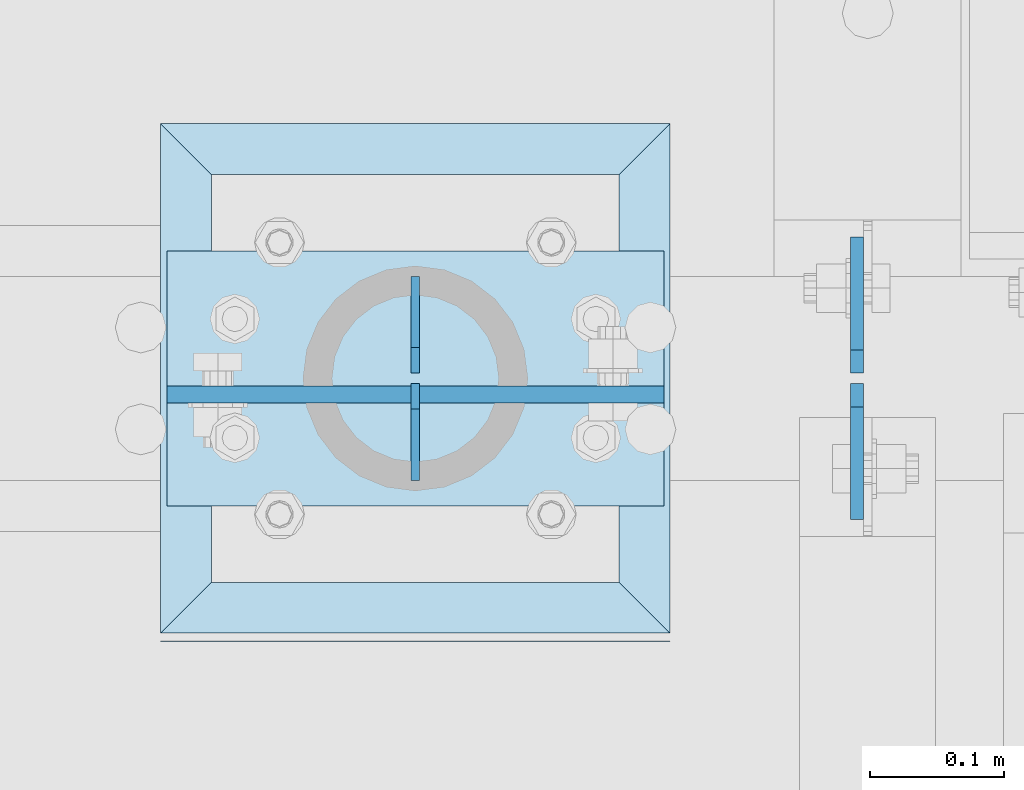
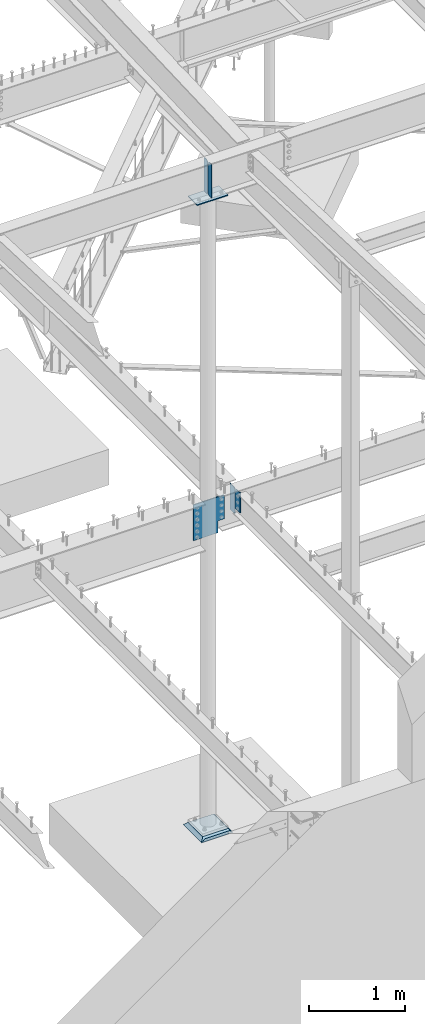
# One storey, part 851 of 975: 7 plates.
"""IFC2X3 building model written with IfcOpenShell, lengths in millimetres."""

from ifc_helpers import new_model, si_unit, frame, origin_with_axes, place, context, subcontext, project, spatial, faceted_brep, material, type_object, element, save


model = new_model("IFC2X3")

# Units and contexts
model_context = context("Model", 3, precision=1e-05, world=origin_with_axes())
body_context = subcontext(model_context, "Body", "Model", "MODEL_VIEW")
ifc_project = project(units=[si_unit("LENGTHUNIT", "METRE", prefix="MILLI"), si_unit("AREAUNIT", "SQUARE_METRE"), si_unit("VOLUMEUNIT", "CUBIC_METRE"), si_unit("MASSUNIT", "GRAM", prefix="KILO"), si_unit("TIMEUNIT", "SECOND"), si_unit("PLANEANGLEUNIT", "RADIAN"), si_unit("SOLIDANGLEUNIT", "STERADIAN"), si_unit("THERMODYNAMICTEMPERATUREUNIT", "DEGREE_CELSIUS"), si_unit("LUMINOUSINTENSITYUNIT", "LUMEN")], contexts=[model_context])

# Site, building, storey
site_placement = place(None, origin_with_axes())
site = spatial("IfcSite", under=ifc_project, at=site_placement, CompositionType="ELEMENT")
building_placement = place(site_placement, origin_with_axes())
building = spatial("IfcBuilding", under=site, at=building_placement, Name="Undefined", CompositionType="ELEMENT")
storey_placement = place(building_placement, origin_with_axes())
storey = spatial("IfcBuildingStorey", under=building, at=storey_placement, Name="Undefined", CompositionType="ELEMENT", Elevation=0.0)

# Plates
ifc_material_1 = material(Name="STEEL/A36")
plate_type_1 = type_object("IfcPlateType", PredefinedType="NOTDEFINED")
plate_1_placement = place(storey_placement, frame((23563.2620000839, 5815.80625, 3670.29999943227), z_axis=(0.0, 0.0, 1.0), x_axis=(0.0, -1.0, 0.0)))
element("IfcPlate", 1, at=plate_1_placement, inside=storey, type_object=plate_type_1, material=ifc_material_1, Name="PLATE", context=body_context, shape_type="Brep", body=[
    faceted_brep([(0.0, -4.76250000000073, 0.0), (0.0, -4.76250000000073, 238.124994277954), (0.0, 4.76250000000073, 238.124994277954), (0.0, 4.76250000000073, 0.0), (17.4624996185303, -4.76250000000073, 255.587493896484), (17.4624996185303, 4.76250000000073, 255.587493896484), (101.600006103508, -4.76250000004075, 255.587493896484), (101.600006103516, 4.76249999995707, 255.587493896484), (101.600006103516, -4.76250000000073, 0.0), (101.600006103516, 4.76250000000073, 0.0)], [[[0, 1, 2, 3]], [[1, 4, 5, 2]], [[4, 6, 7, 5]], [[6, 8, 9, 7]], [[8, 0, 3, 9]], [[5, 7, 9, 3, 2]], [[8, 6, 4, 1, 0]]]),
])
plate_2_placement = place(storey_placement, frame((23563.2625, 5823.74375, 3594.09999943227), z_axis=(0.0, 0.0, 1.0), x_axis=(0.0, 1.0, 0.0)))
element("IfcPlate", 2, at=plate_2_placement, inside=storey, type_object=plate_type_1, material=ifc_material_1, Name="PLATE", context=body_context, shape_type="Brep", body=[
    faceted_brep([(0.0, -4.76250000000073, 0.0), (0.0, -4.76249999999982, 314.325006484985), (0.0, 4.76249999999982, 314.325006484985), (0.0, 4.76250000000073, 0.0), (17.4624996185303, -4.76249999999982, 331.787506103516), (17.4624996185303, 4.76249999999982, 331.787506103516), (101.600006103516, -4.76249999999982, 331.787506103516), (101.600006103516, 4.76249999999982, 331.787506103516), (101.600006103516, -4.76250000000073, 0.0), (101.600006103516, 4.76250000000073, 0.0)], [[[0, 1, 2, 3]], [[1, 4, 5, 2]], [[4, 6, 7, 5]], [[6, 8, 9, 7]], [[8, 0, 3, 9]], [[5, 7, 9, 3, 2]], [[8, 6, 4, 1, 0]]]),
])
plate_type_2 = type_object("IfcPlateType", PredefinedType="NOTDEFINED")
for number, where, z_axis, x_axis, name in (
    (3, (23233.0625, 5743.575, 8218.4875), (0.0, 0.0, -1.0), (0.0, 1.0, 0.0), "PLATE"),
    (4, (23233.0625, 5895.975, 8218.4875), (0.0, 0.0, -1.0), (0.0, -1.0, 0.0), "PLATE"),
):
    element("IfcPlate", number, at=place(storey_placement, frame(where, z_axis=z_axis, x_axis=x_axis)), inside=storey, type_object=plate_type_2, material=ifc_material_1, Name=name, context=body_context, shape_type="Brep", body=[
        faceted_brep([(0.0, -3.17499999999927, 0.0), (0.0, -3.17499999999927, 428.625), (0.0, 3.17499999999927, 428.625), (0.0, 3.17499999999927, 0.0), (53.1812477111816, -3.17499999999927, 428.625), (53.1812477111816, 3.17499999999927, 428.625), (72.2312469482422, -3.17499999999927, 409.575000762939), (72.2312469482422, 3.17499999999927, 409.575000762939), (72.2312469482422, -3.17499999999927, 19.0499992370605), (72.2312469482422, 3.17499999999927, 19.0499992370605), (53.1812477111816, -3.17499999999927, 0.0), (53.1812477111816, 3.17499999999927, 0.0)], [[[0, 1, 2, 3]], [[1, 4, 5, 2]], [[4, 6, 7, 5]], [[6, 8, 9, 7]], [[8, 10, 11, 9]], [[10, 0, 3, 11]], [[5, 7, 9, 11, 3, 2]], [[10, 8, 6, 4, 1, 0]]]),
    ])
plate_type_3 = type_object("IfcPlateType", PredefinedType="NOTDEFINED")
plate_3_placement = place(storey_placement, frame((23418.8, 5915.025, 7772.4), z_axis=(-0.999999999999998, 6.90000001668524e-08, 0.0), x_axis=(0.0, -1.0, 0.0)))
element("IfcPlate", 5, at=plate_3_placement, inside=storey, type_object=plate_type_3, material=ifc_material_1, Name="PLATE", context=body_context, shape_type="Brep", body=[
    faceted_brep([(0.0, -6.34999999998763, -3.63797880709171e-12), (0.0, -6.34999999991669, 371.475006103814), (0.0, 6.35000000008222, 371.475006103821), (0.0, 6.34999999999491, 5.45696821063757e-12), (190.5, -6.34999999991669, 371.475006103814), (190.5, 6.35000000008222, 371.475006103821), (190.5, -6.34999999999764, -1.81898940354586e-12), (190.5, 6.34999999999945, 7.27595761418343e-12)], [[[0, 1, 2, 3]], [[1, 4, 5, 2]], [[4, 6, 7, 5]], [[6, 0, 3, 7]], [[5, 7, 3, 2]], [[6, 4, 1, 0]]]),
])
plate_type_4 = type_object("IfcPlateType", PredefinedType="NOTDEFINED")
plate_4_placement = place(storey_placement, frame((23136.8929941897, 5807.86899986267, 3898.9), z_axis=(0.0, 0.0, -1.0), x_axis=(1.0, 0.0, 0.0)))
element("IfcPlate", 6, at=plate_4_placement, inside=storey, type_object=plate_type_4, material=ifc_material_1, Name="PLATE", context=body_context, shape_type="Brep", body=[
    faceted_brep([(0.0, -6.34999999998763, -3.63797880709171e-12), (-89.6314926147461, -6.35000000000036, 0.0), (-89.6314926147461, 6.35000000000036, 0.0), (0.0, 6.34999999999491, 5.45696821063757e-12), (-89.6314926147461, -6.35000000000036, 457.200012207031), (-89.6314926147461, 6.35000000000036, 457.200012207031), (205.039016723633, -6.35000000000036, 457.200012207031), (205.039016723633, 6.35000000000036, 457.200012207031), (205.039016723633, -6.35000000000036, 319.881237983704), (205.039016723633, 6.35000000000036, 319.881237983704), (206.187008538465, -6.35000000000036, 314.109893396357), (206.187008538465, 6.35000000000036, 314.109893396357), (209.456212635727, -6.35000000000036, 309.217183705064), (209.456212635727, 6.35000000000036, 309.217183705064), (214.348922327019, -6.35000000000036, 305.947979607802), (214.348922327019, 6.35000000000036, 305.947979607802), (220.120266914368, -6.35000000000036, 304.799987792969), (220.120266914368, 6.35000000000036, 304.799987792969), (281.970520019531, -6.35000000000036, 304.799987792969), (281.970520019531, 6.35000000000036, 304.799987792969), (281.970520019531, -6.35000000000036, 0.0), (281.970520019531, 6.35000000000036, 0.0)], [[[0, 1, 2, 3]], [[1, 4, 5, 2]], [[4, 6, 7, 5]], [[6, 8, 9, 7]], [[8, 10, 11, 9]], [[10, 12, 13, 11]], [[12, 14, 15, 13]], [[14, 16, 17, 15]], [[16, 18, 19, 17]], [[18, 20, 21, 19]], [[20, 0, 3, 21]], [[5, 7, 9, 11, 13, 15, 17, 19, 21, 3, 2]], [[20, 18, 16, 14, 12, 10, 8, 6, 4, 1, 0]]]),
])
ifc_material_2 = material(Name="CONCRETE/GROUT")
plate_type_5 = type_object("IfcPlateType", PredefinedType="NOTDEFINED")
plate_5_placement = place(storey_placement, frame((23423.5625, 5622.925, -285.749999999999), z_axis=(-0.999999999999998, 6.90000001668524e-08, 0.0), x_axis=(0.0, 1.0, 0.0)))
element("IfcPlate", 7, at=plate_5_placement, inside=storey, type_object=plate_type_5, material=ifc_material_2, Name="GROUT", context=body_context, shape_type="Brep", body=[
    faceted_brep([(44.4500000000035, -19.05, 342.900000000136), (6.35000000010496, 19.05, 381.0), (6.35000226069315, 19.0499999997364, -1.02318153949454e-11), (44.4500000000035, -19.05, 38.099999999893), (349.249999999983, -19.05, 38.099999999893), (387.350006103516, 19.05, 0.0), (387.350006103516, 19.05, 381.0), (349.249999999983, -19.05, 342.900000000136), (0.693145750610711, 19.05, 381.0), (0.693145750610711, -19.05, 342.900000000136), (0.693145750610711, -19.05, 38.099999999893), (0.693145750610711, 19.05, 0.0), (2.63382389675826e-07, 19.0500000000138, 0.0), (0.0, -19.05, 38.099999999893), (0.0, -19.05, 342.900000000136), (0.0, 19.05, 381.0)], [[[0, 1, 2, 3]], [[4, 5, 6, 7]], [[4, 7, 0, 3]], [[5, 4, 3, 2]], [[6, 5, 2, 1]], [[7, 6, 1, 0]], [[8, 9, 10, 11]], [[12, 13, 14, 15]], [[12, 15, 8, 11]], [[13, 12, 11, 10]], [[14, 13, 10, 9]], [[15, 14, 9, 8]]]),
])

save(model, "model.ifc")
